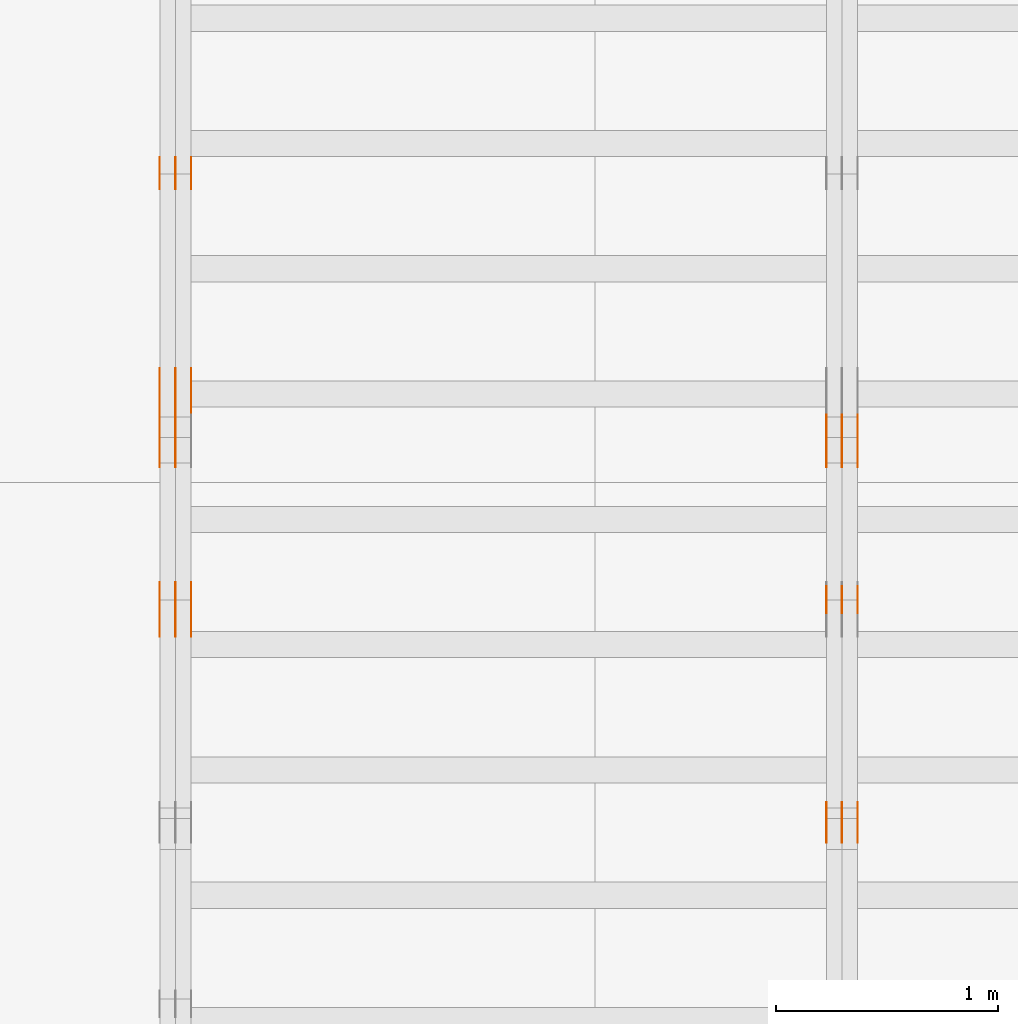
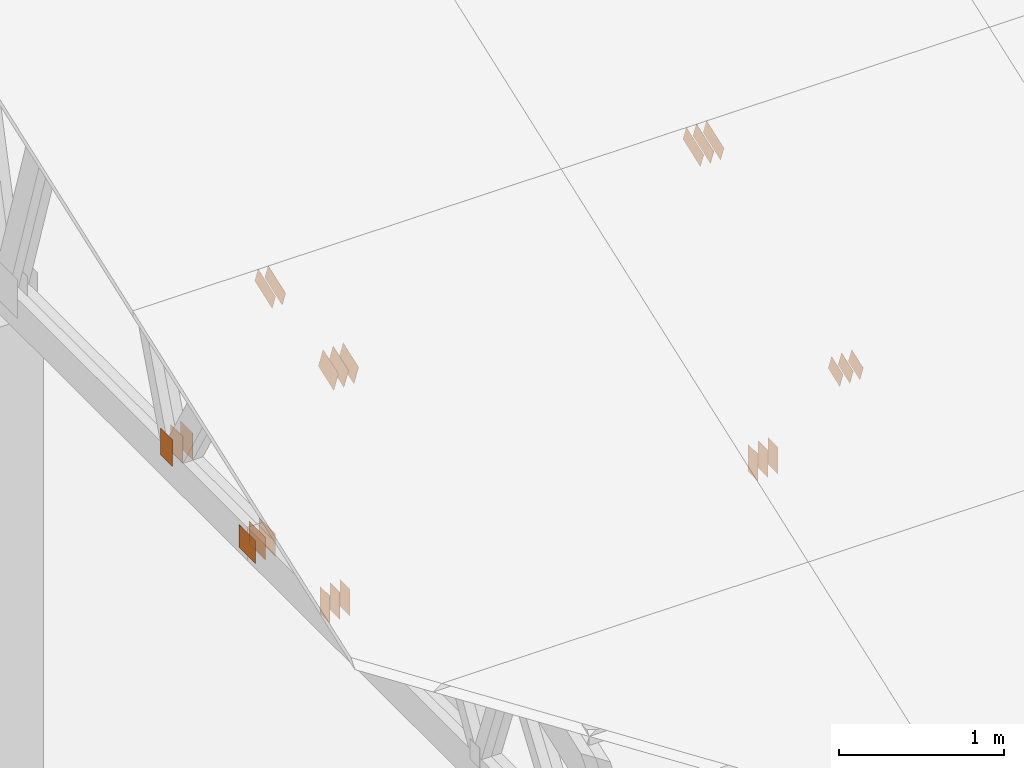
# One storey, part 70 of 189: 31 proxies.
"""IFC2X3 building model written with IfcOpenShell, lengths in millimetres."""

from ifc_helpers import new_model, entity, si_unit, converted_unit, derived_unit, direction, frame, frame_2d, origin, origin_2d_with_axis, place, context, subcontext, project, spatial, polyline, rectangle, outline, extrude, source, transform, mapped, material, type_object, type_shapes, element, save


model = new_model("IFC2X3")

# Units and contexts
model_context = context("Model", 3, precision=0.01, world=origin(), true_north=direction((6.12303176911189e-17, 1.0)))
body_context = subcontext(model_context, "Body", "Model", "MODEL_VIEW")
ifc_project = project(units=[si_unit("LENGTHUNIT", "METRE", prefix="MILLI"), si_unit("AREAUNIT", "SQUARE_METRE"), si_unit("VOLUMEUNIT", "CUBIC_METRE"), converted_unit("PLANEANGLEUNIT", "DEGREE", entity("IfcRatioMeasure", 0.0174532925199433), si_unit("PLANEANGLEUNIT", "RADIAN"), dimensions=[0, 0, 0, 0, 0, 0, 0]), si_unit("MASSUNIT", "GRAM", prefix="KILO"), derived_unit("MASSDENSITYUNIT", [(si_unit("MASSUNIT", "GRAM", prefix="KILO"), 1), (si_unit("LENGTHUNIT", "METRE"), -3)]), si_unit("TIMEUNIT", "SECOND"), si_unit("FREQUENCYUNIT", "HERTZ"), si_unit("THERMODYNAMICTEMPERATUREUNIT", "DEGREE_CELSIUS"), derived_unit("THERMALTRANSMITTANCEUNIT", [(si_unit("MASSUNIT", "GRAM", prefix="KILO"), 1), (si_unit("THERMODYNAMICTEMPERATUREUNIT", "KELVIN"), -1), (si_unit("TIMEUNIT", "SECOND"), -3)]), derived_unit("VOLUMETRICFLOWRATEUNIT", [(si_unit("LENGTHUNIT", "METRE"), 3), (si_unit("TIMEUNIT", "SECOND"), -1)]), si_unit("ELECTRICCURRENTUNIT", "AMPERE"), si_unit("ELECTRICVOLTAGEUNIT", "VOLT"), si_unit("POWERUNIT", "WATT"), si_unit("FORCEUNIT", "NEWTON"), si_unit("ILLUMINANCEUNIT", "LUX"), si_unit("LUMINOUSFLUXUNIT", "LUMEN"), si_unit("LUMINOUSINTENSITYUNIT", "CANDELA"), derived_unit("USERDEFINED", [(si_unit("MASSUNIT", "GRAM", prefix="KILO"), -1), (si_unit("LENGTHUNIT", "METRE"), -2), (si_unit("TIMEUNIT", "SECOND"), 3), (si_unit("LUMINOUSFLUXUNIT", "LUMEN"), 1)]), derived_unit("LINEARVELOCITYUNIT", [(si_unit("LENGTHUNIT", "METRE"), 1), (si_unit("TIMEUNIT", "SECOND"), -1)]), si_unit("PRESSUREUNIT", "PASCAL"), derived_unit("USERDEFINED", [(si_unit("LENGTHUNIT", "METRE"), -2), (si_unit("MASSUNIT", "GRAM", prefix="KILO"), 1), (si_unit("TIMEUNIT", "SECOND"), -2)])], contexts=[model_context])

# Site, building, storey
site_placement = place(None, origin())
site = spatial("IfcSite", under=ifc_project, at=site_placement, CompositionType="ELEMENT")
building_placement = place(site_placement, origin())
building = spatial("IfcBuilding", under=site, at=building_placement, CompositionType="ELEMENT")
storey_placement = place(building_placement, origin())
storey = spatial("IfcBuildingStorey", under=building, at=storey_placement, Name="Default", CompositionType="ELEMENT", Elevation=0.0)

# Proxies
ifc_material_1 = material(Name="IfcSurfaceStyle #27756")
building_element_proxy_type_1 = type_object("IfcBuildingElementProxyType", PredefinedType="NOTDEFINED", material=ifc_material_1)
shared_shape_1 = source(origin(), body_context, "Body", "SweptSolid", [
    extrude(outline(polyline([(-112.500654374667, -59.9999021691247), (112.500117969231, -59.9999021691247), (112.500612624162, 59.9999021691247), (-112.500076218726, 59.9999021691247), (-112.500654374667, -59.9999021691247)])), frame((112.500612624162, 60.0003514046321, 0.0), z_axis=(0.0, 0.0, 1.0), x_axis=(-1.0, 0.0, 0.0)), (0.0, 0.0, 1.0), 1.3),
])
type_shapes(building_element_proxy_type_1, [shared_shape_1])
proxy_1_placement = place(building_placement, frame((3336.3, 5418.0703125, 2162.37353515625), z_axis=(-1.0, 0.0, 0.0), x_axis=(0.0, 0.939692620785908, 0.342020143325669)))
element("IfcBuildingElementProxy", 1, at=proxy_1_placement, inside=storey, type_object=building_element_proxy_type_1, material=ifc_material_1, context=body_context, shape_type="MappedRepresentation", body=[
    mapped(shared_shape_1, transform((0.0, 0.0, 0.0), scale=1.0)),
])
ifc_material_2 = material(Name="IfcSurfaceStyle #27699")
building_element_proxy_type_2 = type_object("IfcBuildingElementProxyType", PredefinedType="NOTDEFINED", material=ifc_material_2)
shared_shape_2 = source(origin(), body_context, "Body", "SweptSolid", [
    extrude(outline(polyline([(-112.500654374667, -59.9999021691247), (112.500117969231, -59.9999021691247), (112.500612624162, 59.9999021691247), (-112.500076218726, 59.9999021691247), (-112.500654374667, -59.9999021691247)])), frame((112.500612624162, 60.0003514046321, 0.0), z_axis=(0.0, 0.0, 1.0), x_axis=(-1.0, 0.0, 0.0)), (0.0, 0.0, 1.0), 1.29999999999998),
])
type_shapes(building_element_proxy_type_2, [shared_shape_2])
proxy_2_placement = place(building_placement, frame((3265.0, 5418.0703125, 2162.37353515625), z_axis=(-1.0, 0.0, 0.0), x_axis=(0.0, 0.939692620785908, 0.342020143325669)))
element("IfcBuildingElementProxy", 2, at=proxy_2_placement, inside=storey, type_object=building_element_proxy_type_2, material=ifc_material_2, context=body_context, shape_type="MappedRepresentation", body=[
    mapped(shared_shape_2, transform((0.0, 0.0, 0.0), scale=1.0)),
])
ifc_material_3 = material(Name="IfcSurfaceStyle #27642")
building_element_proxy_type_3 = type_object("IfcBuildingElementProxyType", PredefinedType="NOTDEFINED", material=ifc_material_3)
shared_shape_3 = source(origin(), body_context, "Body", "SweptSolid", [
    extrude(outline(polyline([(-112.500654374667, -59.9999021691247), (112.500117969231, -59.9999021691247), (112.500612624162, 59.9999021691247), (-112.500076218726, 59.9999021691247), (-112.500654374667, -59.9999021691247)])), frame((112.500612624162, 60.0003514046321, 0.0), z_axis=(0.0, 0.0, 1.0), x_axis=(-1.0, 0.0, 0.0)), (0.0, 0.0, 1.0), 1.29999999999998),
])
type_shapes(building_element_proxy_type_3, [shared_shape_3])
proxy_3_placement = place(building_placement, frame((3266.3, 5418.0703125, 2162.37353515625), z_axis=(-1.0, 0.0, 0.0), x_axis=(0.0, 0.939692620785908, 0.342020143325669)))
element("IfcBuildingElementProxy", 3, at=proxy_3_placement, inside=storey, type_object=building_element_proxy_type_3, material=ifc_material_3, context=body_context, shape_type="MappedRepresentation", body=[
    mapped(shared_shape_3, transform((0.0, 0.0, 0.0), scale=1.0)),
])
ifc_material_4 = material(Name="IfcSurfaceStyle #27585")
building_element_proxy_type_4 = type_object("IfcBuildingElementProxyType", PredefinedType="NOTDEFINED", material=ifc_material_4)
shared_shape_4 = source(origin(), body_context, "Body", "SweptSolid", [
    extrude(outline(polyline([(-112.500654374667, -59.9999021691247), (112.500117969231, -59.9999021691247), (112.500612624162, 59.9999021691247), (-112.500076218726, 59.9999021691247), (-112.500654374667, -59.9999021691247)])), frame((112.500612624162, 60.0003514046321, 0.0), z_axis=(0.0, 0.0, 1.0), x_axis=(-1.0, 0.0, 0.0)), (0.0, 0.0, 1.0), 1.29999999999999),
])
type_shapes(building_element_proxy_type_4, [shared_shape_4])
proxy_4_placement = place(building_placement, frame((3195.0, 5418.0703125, 2162.37353515625), z_axis=(-1.0, 0.0, 0.0), x_axis=(0.0, 0.939692620785908, 0.342020143325669)))
element("IfcBuildingElementProxy", 4, at=proxy_4_placement, inside=storey, type_object=building_element_proxy_type_4, material=ifc_material_4, context=body_context, shape_type="MappedRepresentation", body=[
    mapped(shared_shape_4, transform((0.0, 0.0, 0.0), scale=1.0)),
])
ifc_material_5 = material(Name="IfcSurfaceStyle #27072")
building_element_proxy_type_5 = type_object("IfcBuildingElementProxyType", PredefinedType="NOTDEFINED", material=ifc_material_5)
shared_shape_5 = source(origin(), body_context, "Body", "SweptSolid", [
    extrude(rectangle(XDim=200.0, YDim=120.0, at=origin_2d_with_axis()), frame((100.0, 60.0, 0.0), z_axis=(0.0, 0.0, 1.0), x_axis=(-1.0, 0.0, 0.0)), (0.0, 0.0, 1.0), 1.3),
])
type_shapes(building_element_proxy_type_5, [shared_shape_5])
proxy_5_placement = place(building_placement, frame((3336.3, 4760.65625, 145.0), z_axis=(-1.0, 0.0, 0.0), x_axis=(0.0, 0.0, 1.0)))
element("IfcBuildingElementProxy", 5, at=proxy_5_placement, inside=storey, type_object=building_element_proxy_type_5, material=ifc_material_5, context=body_context, shape_type="MappedRepresentation", body=[
    mapped(shared_shape_5, transform((0.0, 0.0, 0.0), scale=1.0)),
])
ifc_material_6 = material(Name="IfcSurfaceStyle #27015")
building_element_proxy_type_6 = type_object("IfcBuildingElementProxyType", PredefinedType="NOTDEFINED", material=ifc_material_6)
shared_shape_6 = source(origin(), body_context, "Body", "SweptSolid", [
    extrude(rectangle(XDim=200.0, YDim=120.0, at=origin_2d_with_axis()), frame((100.0, 60.0, 0.0), z_axis=(0.0, 0.0, 1.0), x_axis=(-1.0, 0.0, 0.0)), (0.0, 0.0, 1.0), 1.29999999999998),
])
type_shapes(building_element_proxy_type_6, [shared_shape_6])
proxy_6_placement = place(building_placement, frame((3265.0, 4760.65625, 145.0), z_axis=(-1.0, 0.0, 0.0), x_axis=(0.0, 0.0, 1.0)))
element("IfcBuildingElementProxy", 6, at=proxy_6_placement, inside=storey, type_object=building_element_proxy_type_6, material=ifc_material_6, context=body_context, shape_type="MappedRepresentation", body=[
    mapped(shared_shape_6, transform((0.0, 0.0, 0.0), scale=1.0)),
])
ifc_material_7 = material(Name="IfcSurfaceStyle #26958")
building_element_proxy_type_7 = type_object("IfcBuildingElementProxyType", PredefinedType="NOTDEFINED", material=ifc_material_7)
shared_shape_7 = source(origin(), body_context, "Body", "SweptSolid", [
    extrude(rectangle(XDim=200.0, YDim=120.0, at=origin_2d_with_axis()), frame((100.0, 60.0, 0.0), z_axis=(0.0, 0.0, 1.0), x_axis=(-1.0, 0.0, 0.0)), (0.0, 0.0, 1.0), 1.29999999999998),
])
type_shapes(building_element_proxy_type_7, [shared_shape_7])
proxy_7_placement = place(building_placement, frame((3266.3, 4760.65625, 145.0), z_axis=(-1.0, 0.0, 0.0), x_axis=(0.0, 0.0, 1.0)))
element("IfcBuildingElementProxy", 7, at=proxy_7_placement, inside=storey, type_object=building_element_proxy_type_7, material=ifc_material_7, context=body_context, shape_type="MappedRepresentation", body=[
    mapped(shared_shape_7, transform((0.0, 0.0, 0.0), scale=1.0)),
])
ifc_material_8 = material(Name="IfcSurfaceStyle #26901")
building_element_proxy_type_8 = type_object("IfcBuildingElementProxyType", PredefinedType="NOTDEFINED", material=ifc_material_8)
shared_shape_8 = source(origin(), body_context, "Body", "SweptSolid", [
    extrude(rectangle(XDim=200.0, YDim=120.0, at=origin_2d_with_axis()), frame((100.0, 60.0, 0.0), z_axis=(0.0, 0.0, 1.0), x_axis=(-1.0, 0.0, 0.0)), (0.0, 0.0, 1.0), 1.29999999999999),
])
type_shapes(building_element_proxy_type_8, [shared_shape_8])
proxy_8_placement = place(building_placement, frame((3195.0, 4760.65625, 145.0), z_axis=(-1.0, 0.0, 0.0), x_axis=(0.0, 0.0, 1.0)))
element("IfcBuildingElementProxy", 8, at=proxy_8_placement, inside=storey, type_object=building_element_proxy_type_8, material=ifc_material_8, context=body_context, shape_type="MappedRepresentation", body=[
    mapped(shared_shape_8, transform((0.0, 0.0, 0.0), scale=1.0)),
])
ifc_material_9 = material(Name="IfcSurfaceStyle #26844")
building_element_proxy_type_9 = type_object("IfcBuildingElementProxyType", PredefinedType="NOTDEFINED", material=ifc_material_9)
shared_shape_9 = source(origin(), body_context, "Body", "SweptSolid", [
    extrude(outline(polyline([(-74.9994515581384, -59.9999039432178), (74.9998536965286, -59.9999039432178), (75.0003483514593, 59.9999039432178), (-75.0007504898495, 59.9999039432178), (-74.9994515581384, -59.9999039432178)])), frame((75.0003483514593, 60.0003496305408, 0.0), z_axis=(0.0, 0.0, 1.0), x_axis=(-1.0, 0.0, 0.0)), (0.0, 0.0, 1.0), 1.3),
])
type_shapes(building_element_proxy_type_9, [shared_shape_9])
proxy_9_placement = place(building_placement, frame((3336.3, 3726.8984375, 1559.607421875), z_axis=(-1.0, 0.0, 0.0), x_axis=(0.0, 0.939692620785908, 0.342020143325669)))
element("IfcBuildingElementProxy", 9, at=proxy_9_placement, inside=storey, type_object=building_element_proxy_type_9, material=ifc_material_9, context=body_context, shape_type="MappedRepresentation", body=[
    mapped(shared_shape_9, transform((0.0, 0.0, 0.0), scale=1.0)),
])
ifc_material_10 = material(Name="IfcSurfaceStyle #26787")
building_element_proxy_type_10 = type_object("IfcBuildingElementProxyType", PredefinedType="NOTDEFINED", material=ifc_material_10)
shared_shape_10 = source(origin(), body_context, "Body", "SweptSolid", [
    extrude(outline(polyline([(-74.9994515581384, -59.9999039432178), (74.9998536965286, -59.9999039432178), (75.0003483514593, 59.9999039432178), (-75.0007504898495, 59.9999039432178), (-74.9994515581384, -59.9999039432178)])), frame((75.0003483514593, 60.0003496305408, 0.0), z_axis=(0.0, 0.0, 1.0), x_axis=(-1.0, 0.0, 0.0)), (0.0, 0.0, 1.0), 1.29999999999999),
])
type_shapes(building_element_proxy_type_10, [shared_shape_10])
proxy_10_placement = place(building_placement, frame((3265.0, 3726.8984375, 1559.607421875), z_axis=(-1.0, 0.0, 0.0), x_axis=(0.0, 0.939692620785908, 0.342020143325669)))
element("IfcBuildingElementProxy", 10, at=proxy_10_placement, inside=storey, type_object=building_element_proxy_type_10, material=ifc_material_10, context=body_context, shape_type="MappedRepresentation", body=[
    mapped(shared_shape_10, transform((0.0, 0.0, 0.0), scale=1.0)),
])
ifc_material_11 = material(Name="IfcSurfaceStyle #26730")
building_element_proxy_type_11 = type_object("IfcBuildingElementProxyType", PredefinedType="NOTDEFINED", material=ifc_material_11)
shared_shape_11 = source(origin(), body_context, "Body", "SweptSolid", [
    extrude(outline(polyline([(-74.9994515581384, -59.9999039432178), (74.9998536965286, -59.9999039432178), (75.0003483514593, 59.9999039432178), (-75.0007504898495, 59.9999039432178), (-74.9994515581384, -59.9999039432178)])), frame((75.0003483514593, 60.0003496305408, 0.0), z_axis=(0.0, 0.0, 1.0), x_axis=(-1.0, 0.0, 0.0)), (0.0, 0.0, 1.0), 1.29999999999999),
])
type_shapes(building_element_proxy_type_11, [shared_shape_11])
proxy_11_placement = place(building_placement, frame((3266.3, 3726.8984375, 1559.607421875), z_axis=(-1.0, 0.0, 0.0), x_axis=(0.0, 0.939692620785908, 0.342020143325669)))
element("IfcBuildingElementProxy", 11, at=proxy_11_placement, inside=storey, type_object=building_element_proxy_type_11, material=ifc_material_11, context=body_context, shape_type="MappedRepresentation", body=[
    mapped(shared_shape_11, transform((0.0, 0.0, 0.0), scale=1.0)),
])
ifc_material_12 = material(Name="IfcSurfaceStyle #26673")
building_element_proxy_type_12 = type_object("IfcBuildingElementProxyType", PredefinedType="NOTDEFINED", material=ifc_material_12)
shared_shape_12 = source(origin(), body_context, "Body", "SweptSolid", [
    extrude(outline(polyline([(-74.9994515581384, -59.9999039432178), (74.9998536965286, -59.9999039432178), (75.0003483514593, 59.9999039432178), (-75.0007504898495, 59.9999039432178), (-74.9994515581384, -59.9999039432178)])), frame((75.0003483514593, 60.0003496305408, 0.0), z_axis=(0.0, 0.0, 1.0), x_axis=(-1.0, 0.0, 0.0)), (0.0, 0.0, 1.0), 1.29999999999999),
])
type_shapes(building_element_proxy_type_12, [shared_shape_12])
proxy_12_placement = place(building_placement, frame((3195.0, 3726.8984375, 1559.607421875), z_axis=(-1.0, 0.0, 0.0), x_axis=(0.0, 0.939692620785908, 0.342020143325669)))
element("IfcBuildingElementProxy", 12, at=proxy_12_placement, inside=storey, type_object=building_element_proxy_type_12, material=ifc_material_12, context=body_context, shape_type="MappedRepresentation", body=[
    mapped(shared_shape_12, transform((0.0, 0.0, 0.0), scale=1.0)),
])
ifc_material_13 = material(Name="IfcSurfaceStyle #15839")
building_element_proxy_type_13 = type_object("IfcBuildingElementProxyType", PredefinedType="NOTDEFINED", material=ifc_material_13)
shared_shape_13 = source(origin(), body_context, "Body", "SweptSolid", [
    extrude(rectangle(XDim=200.0, YDim=144.0, at=frame_2d((1.4210854715202e-14, 0.0), x_axis=(1.0, 0.0))), frame((100.0, 72.0, 0.0), z_axis=(0.0, 0.0, 1.0), x_axis=(-1.0, 0.0, 0.0)), (0.0, 0.0, 1.0), 1.3),
])
type_shapes(building_element_proxy_type_13, [shared_shape_13])
proxy_13_placement = place(building_placement, frame((336.3, 6668.833984375, 145.0), z_axis=(-1.0, 0.0, 0.0), x_axis=(0.0, 0.0, 1.0)))
element("IfcBuildingElementProxy", 13, at=proxy_13_placement, inside=storey, type_object=building_element_proxy_type_13, material=ifc_material_13, context=body_context, shape_type="MappedRepresentation", body=[
    mapped(shared_shape_13, transform((0.0, 0.0, 0.0), scale=1.0)),
])
ifc_material_14 = material(Name="IfcSurfaceStyle #15782")
building_element_proxy_type_14 = type_object("IfcBuildingElementProxyType", PredefinedType="NOTDEFINED", material=ifc_material_14)
shared_shape_14 = source(origin(), body_context, "Body", "SweptSolid", [
    extrude(rectangle(XDim=200.0, YDim=144.0, at=frame_2d((1.4210854715202e-14, 0.0), x_axis=(1.0, 0.0))), frame((100.0, 72.0, 0.0), z_axis=(0.0, 0.0, 1.0), x_axis=(-1.0, 0.0, 0.0)), (0.0, 0.0, 1.0), 1.29999999999998),
])
type_shapes(building_element_proxy_type_14, [shared_shape_14])
proxy_14_placement = place(building_placement, frame((265.0, 6668.833984375, 145.0), z_axis=(-1.0, 0.0, 0.0), x_axis=(0.0, 0.0, 1.0)))
element("IfcBuildingElementProxy", 14, at=proxy_14_placement, inside=storey, type_object=building_element_proxy_type_14, material=ifc_material_14, context=body_context, shape_type="MappedRepresentation", body=[
    mapped(shared_shape_14, transform((0.0, 0.0, 0.0), scale=1.0)),
])
ifc_material_15 = material(Name="IfcSurfaceStyle #15725")
building_element_proxy_type_15 = type_object("IfcBuildingElementProxyType", PredefinedType="NOTDEFINED", material=ifc_material_15)
shared_shape_15 = source(origin(), body_context, "Body", "SweptSolid", [
    extrude(rectangle(XDim=200.0, YDim=144.0, at=frame_2d((1.4210854715202e-14, 0.0), x_axis=(1.0, 0.0))), frame((100.0, 72.0, 0.0), z_axis=(0.0, 0.0, 1.0), x_axis=(-1.0, 0.0, 0.0)), (0.0, 0.0, 1.0), 1.29999999999998),
])
type_shapes(building_element_proxy_type_15, [shared_shape_15])
proxy_15_placement = place(building_placement, frame((266.3, 6668.833984375, 145.0), z_axis=(-1.0, 0.0, 0.0), x_axis=(0.0, 0.0, 1.0)))
element("IfcBuildingElementProxy", 15, at=proxy_15_placement, inside=storey, type_object=building_element_proxy_type_15, material=ifc_material_15, context=body_context, shape_type="MappedRepresentation", body=[
    mapped(shared_shape_15, transform((0.0, 0.0, 0.0), scale=1.0)),
])
ifc_material_16 = material(Name="IfcSurfaceStyle #15668")
building_element_proxy_type_16 = type_object("IfcBuildingElementProxyType", PredefinedType="NOTDEFINED", material=ifc_material_16)
shared_shape_16 = source(origin(), body_context, "Body", "SweptSolid", [
    extrude(rectangle(XDim=200.0, YDim=144.0, at=frame_2d((1.4210854715202e-14, 0.0), x_axis=(1.0, 0.0))), frame((100.0, 72.0, 0.0), z_axis=(0.0, 0.0, 1.0), x_axis=(-1.0, 0.0, 0.0)), (0.0, 0.0, 1.0), 1.29999999999999),
])
type_shapes(building_element_proxy_type_16, [shared_shape_16])
proxy_16_placement = place(building_placement, frame((195.0, 6668.833984375, 145.0), z_axis=(-1.0, 0.0, 0.0), x_axis=(0.0, 0.0, 1.0)))
element("IfcBuildingElementProxy", 16, at=proxy_16_placement, inside=storey, type_object=building_element_proxy_type_16, material=ifc_material_16, context=body_context, shape_type="MappedRepresentation", body=[
    mapped(shared_shape_16, transform((0.0, 0.0, 0.0), scale=1.0)),
])
ifc_material_17 = material(Name="IfcSurfaceStyle #15611")
building_element_proxy_type_17 = type_object("IfcBuildingElementProxyType", PredefinedType="NOTDEFINED", material=ifc_material_17)
shared_shape_17 = source(origin(), body_context, "Body", "SweptSolid", [
    extrude(rectangle(XDim=200.0, YDim=168.0, at=origin_2d_with_axis()), frame((100.0, 84.0, 0.0), z_axis=(0.0, 0.0, 1.0), x_axis=(-1.0, 0.0, 0.0)), (0.0, 0.0, 1.0), 1.3),
])
type_shapes(building_element_proxy_type_17, [shared_shape_17])
proxy_17_placement = place(building_placement, frame((336.3, 5662.466796875, 206.5), z_axis=(-1.0, 0.0, 0.0), x_axis=(0.0, 1.0, 0.0)))
element("IfcBuildingElementProxy", 17, at=proxy_17_placement, inside=storey, type_object=building_element_proxy_type_17, material=ifc_material_17, context=body_context, shape_type="MappedRepresentation", body=[
    mapped(shared_shape_17, transform((0.0, 0.0, 0.0), scale=1.0)),
])
ifc_material_18 = material(Name="IfcSurfaceStyle #15554")
building_element_proxy_type_18 = type_object("IfcBuildingElementProxyType", PredefinedType="NOTDEFINED", material=ifc_material_18)
shared_shape_18 = source(origin(), body_context, "Body", "SweptSolid", [
    extrude(rectangle(XDim=200.0, YDim=168.0, at=origin_2d_with_axis()), frame((100.0, 84.0, 0.0), z_axis=(0.0, 0.0, 1.0), x_axis=(-1.0, 0.0, 0.0)), (0.0, 0.0, 1.0), 1.29999999999998),
])
type_shapes(building_element_proxy_type_18, [shared_shape_18])
proxy_18_placement = place(building_placement, frame((265.0, 5662.466796875, 206.5), z_axis=(-1.0, 0.0, 0.0), x_axis=(0.0, 1.0, 0.0)))
element("IfcBuildingElementProxy", 18, at=proxy_18_placement, inside=storey, type_object=building_element_proxy_type_18, material=ifc_material_18, context=body_context, shape_type="MappedRepresentation", body=[
    mapped(shared_shape_18, transform((0.0, 0.0, 0.0), scale=1.0)),
])
ifc_material_19 = material(Name="IfcSurfaceStyle #15497")
building_element_proxy_type_19 = type_object("IfcBuildingElementProxyType", PredefinedType="NOTDEFINED", material=ifc_material_19)
shared_shape_19 = source(origin(), body_context, "Body", "SweptSolid", [
    extrude(rectangle(XDim=200.0, YDim=168.0, at=origin_2d_with_axis()), frame((100.0, 84.0, 0.0), z_axis=(0.0, 0.0, 1.0), x_axis=(-1.0, 0.0, 0.0)), (0.0, 0.0, 1.0), 1.29999999999998),
])
type_shapes(building_element_proxy_type_19, [shared_shape_19])
proxy_19_placement = place(building_placement, frame((266.3, 5662.466796875, 206.5), z_axis=(-1.0, 0.0, 0.0), x_axis=(0.0, 1.0, 0.0)))
element("IfcBuildingElementProxy", 19, at=proxy_19_placement, inside=storey, type_object=building_element_proxy_type_19, material=ifc_material_19, context=body_context, shape_type="MappedRepresentation", body=[
    mapped(shared_shape_19, transform((0.0, 0.0, 0.0), scale=1.0)),
])
ifc_material_20 = material(Name="IfcSurfaceStyle #15440")
building_element_proxy_type_20 = type_object("IfcBuildingElementProxyType", PredefinedType="NOTDEFINED", material=ifc_material_20)
shared_shape_20 = source(origin(), body_context, "Body", "SweptSolid", [
    extrude(rectangle(XDim=200.0, YDim=168.0, at=origin_2d_with_axis()), frame((100.0, 84.0, 0.0), z_axis=(0.0, 0.0, 1.0), x_axis=(-1.0, 0.0, 0.0)), (0.0, 0.0, 1.0), 1.29999999999999),
])
type_shapes(building_element_proxy_type_20, [shared_shape_20])
proxy_20_placement = place(building_placement, frame((195.0, 5662.466796875, 206.5), z_axis=(-1.0, 0.0, 0.0), x_axis=(0.0, 1.0, 0.0)))
element("IfcBuildingElementProxy", 20, at=proxy_20_placement, inside=storey, type_object=building_element_proxy_type_20, material=ifc_material_20, context=body_context, shape_type="MappedRepresentation", body=[
    mapped(shared_shape_20, transform((0.0, 0.0, 0.0), scale=1.0)),
])
ifc_material_21 = material(Name="IfcSurfaceStyle #11906")
building_element_proxy_type_21 = type_object("IfcBuildingElementProxyType", PredefinedType="NOTDEFINED", material=ifc_material_21)
shared_shape_21 = source(origin(), body_context, "Body", "SweptSolid", [
    extrude(outline(polyline([(-112.500654374667, -59.9999021691247), (112.500117969231, -59.9999021691247), (112.500612624162, 59.9999021691247), (-112.500076218726, 59.9999021691247), (-112.500654374667, -59.9999021691247)])), frame((112.500612624162, 60.0003514046321, 0.0), z_axis=(0.0, 0.0, 1.0), x_axis=(-1.0, 0.0, 0.0)), (0.0, 0.0, 1.0), 1.29999999999998),
])
type_shapes(building_element_proxy_type_21, [shared_shape_21])
proxy_21_placement = place(building_placement, frame((265.0, 5418.0703125, 2162.37353515625), z_axis=(-1.0, 0.0, 0.0), x_axis=(0.0, 0.939692620785908, 0.342020143325669)))
element("IfcBuildingElementProxy", 21, at=proxy_21_placement, inside=storey, type_object=building_element_proxy_type_21, material=ifc_material_21, context=body_context, shape_type="MappedRepresentation", body=[
    mapped(shared_shape_21, transform((0.0, 0.0, 0.0), scale=1.0)),
])
ifc_material_22 = material(Name="IfcSurfaceStyle #11849")
building_element_proxy_type_22 = type_object("IfcBuildingElementProxyType", PredefinedType="NOTDEFINED", material=ifc_material_22)
shared_shape_22 = source(origin(), body_context, "Body", "SweptSolid", [
    extrude(outline(polyline([(-112.500654374667, -59.9999021691247), (112.500117969231, -59.9999021691247), (112.500612624162, 59.9999021691247), (-112.500076218726, 59.9999021691247), (-112.500654374667, -59.9999021691247)])), frame((112.500612624162, 60.0003514046321, 0.0), z_axis=(0.0, 0.0, 1.0), x_axis=(-1.0, 0.0, 0.0)), (0.0, 0.0, 1.0), 1.29999999999998),
])
type_shapes(building_element_proxy_type_22, [shared_shape_22])
proxy_22_placement = place(building_placement, frame((266.3, 5418.0703125, 2162.37353515625), z_axis=(-1.0, 0.0, 0.0), x_axis=(0.0, 0.939692620785908, 0.342020143325669)))
element("IfcBuildingElementProxy", 22, at=proxy_22_placement, inside=storey, type_object=building_element_proxy_type_22, material=ifc_material_22, context=body_context, shape_type="MappedRepresentation", body=[
    mapped(shared_shape_22, transform((0.0, 0.0, 0.0), scale=1.0)),
])
ifc_material_23 = material(Name="IfcSurfaceStyle #11792")
building_element_proxy_type_23 = type_object("IfcBuildingElementProxyType", PredefinedType="NOTDEFINED", material=ifc_material_23)
shared_shape_23 = source(origin(), body_context, "Body", "SweptSolid", [
    extrude(outline(polyline([(-112.500654374667, -59.9999021691247), (112.500117969231, -59.9999021691247), (112.500612624162, 59.9999021691247), (-112.500076218726, 59.9999021691247), (-112.500654374667, -59.9999021691247)])), frame((112.500612624162, 60.0003514046321, 0.0), z_axis=(0.0, 0.0, 1.0), x_axis=(-1.0, 0.0, 0.0)), (0.0, 0.0, 1.0), 1.29999999999999),
])
type_shapes(building_element_proxy_type_23, [shared_shape_23])
proxy_23_placement = place(building_placement, frame((195.0, 5418.0703125, 2162.37353515625), z_axis=(-1.0, 0.0, 0.0), x_axis=(0.0, 0.939692620785908, 0.342020143325669)))
element("IfcBuildingElementProxy", 23, at=proxy_23_placement, inside=storey, type_object=building_element_proxy_type_23, material=ifc_material_23, context=body_context, shape_type="MappedRepresentation", body=[
    mapped(shared_shape_23, transform((0.0, 0.0, 0.0), scale=1.0)),
])
ifc_material_24 = material(Name="IfcSurfaceStyle #11279")
building_element_proxy_type_24 = type_object("IfcBuildingElementProxyType", PredefinedType="NOTDEFINED", material=ifc_material_24)
shared_shape_24 = source(origin(), body_context, "Body", "SweptSolid", [
    extrude(rectangle(XDim=200.0, YDim=120.0, at=origin_2d_with_axis()), frame((100.0, 60.0, 0.0), z_axis=(0.0, 0.0, 1.0), x_axis=(-1.0, 0.0, 0.0)), (0.0, 0.0, 1.0), 1.3),
])
type_shapes(building_element_proxy_type_24, [shared_shape_24])
proxy_24_placement = place(building_placement, frame((336.3, 4760.65625, 145.0), z_axis=(-1.0, 0.0, 0.0), x_axis=(0.0, 0.0, 1.0)))
element("IfcBuildingElementProxy", 24, at=proxy_24_placement, inside=storey, type_object=building_element_proxy_type_24, material=ifc_material_24, context=body_context, shape_type="MappedRepresentation", body=[
    mapped(shared_shape_24, transform((0.0, 0.0, 0.0), scale=1.0)),
])
ifc_material_25 = material(Name="IfcSurfaceStyle #11222")
building_element_proxy_type_25 = type_object("IfcBuildingElementProxyType", PredefinedType="NOTDEFINED", material=ifc_material_25)
shared_shape_25 = source(origin(), body_context, "Body", "SweptSolid", [
    extrude(rectangle(XDim=200.0, YDim=120.0, at=origin_2d_with_axis()), frame((100.0, 60.0, 0.0), z_axis=(0.0, 0.0, 1.0), x_axis=(-1.0, 0.0, 0.0)), (0.0, 0.0, 1.0), 1.29999999999998),
])
type_shapes(building_element_proxy_type_25, [shared_shape_25])
proxy_25_placement = place(building_placement, frame((265.0, 4760.65625, 145.0), z_axis=(-1.0, 0.0, 0.0), x_axis=(0.0, 0.0, 1.0)))
element("IfcBuildingElementProxy", 25, at=proxy_25_placement, inside=storey, type_object=building_element_proxy_type_25, material=ifc_material_25, context=body_context, shape_type="MappedRepresentation", body=[
    mapped(shared_shape_25, transform((0.0, 0.0, 0.0), scale=1.0)),
])
ifc_material_26 = material(Name="IfcSurfaceStyle #11165")
building_element_proxy_type_26 = type_object("IfcBuildingElementProxyType", PredefinedType="NOTDEFINED", material=ifc_material_26)
shared_shape_26 = source(origin(), body_context, "Body", "SweptSolid", [
    extrude(rectangle(XDim=200.0, YDim=120.0, at=origin_2d_with_axis()), frame((100.0, 60.0, 0.0), z_axis=(0.0, 0.0, 1.0), x_axis=(-1.0, 0.0, 0.0)), (0.0, 0.0, 1.0), 1.29999999999998),
])
type_shapes(building_element_proxy_type_26, [shared_shape_26])
proxy_26_placement = place(building_placement, frame((266.3, 4760.65625, 145.0), z_axis=(-1.0, 0.0, 0.0), x_axis=(0.0, 0.0, 1.0)))
element("IfcBuildingElementProxy", 26, at=proxy_26_placement, inside=storey, type_object=building_element_proxy_type_26, material=ifc_material_26, context=body_context, shape_type="MappedRepresentation", body=[
    mapped(shared_shape_26, transform((0.0, 0.0, 0.0), scale=1.0)),
])
ifc_material_27 = material(Name="IfcSurfaceStyle #11108")
building_element_proxy_type_27 = type_object("IfcBuildingElementProxyType", PredefinedType="NOTDEFINED", material=ifc_material_27)
shared_shape_27 = source(origin(), body_context, "Body", "SweptSolid", [
    extrude(rectangle(XDim=200.0, YDim=120.0, at=origin_2d_with_axis()), frame((100.0, 60.0, 0.0), z_axis=(0.0, 0.0, 1.0), x_axis=(-1.0, 0.0, 0.0)), (0.0, 0.0, 1.0), 1.29999999999999),
])
type_shapes(building_element_proxy_type_27, [shared_shape_27])
proxy_27_placement = place(building_placement, frame((195.0, 4760.65625, 145.0), z_axis=(-1.0, 0.0, 0.0), x_axis=(0.0, 0.0, 1.0)))
element("IfcBuildingElementProxy", 27, at=proxy_27_placement, inside=storey, type_object=building_element_proxy_type_27, material=ifc_material_27, context=body_context, shape_type="MappedRepresentation", body=[
    mapped(shared_shape_27, transform((0.0, 0.0, 0.0), scale=1.0)),
])
ifc_material_28 = material(Name="IfcSurfaceStyle #6383")
building_element_proxy_type_28 = type_object("IfcBuildingElementProxyType", PredefinedType="NOTDEFINED", material=ifc_material_28)
shared_shape_28 = source(origin(), body_context, "Body", "SweptSolid", [
    extrude(outline(polyline([(-99.9993269270171, -84.0000832532405), (99.9997189122032, -84.0000832532405), (99.9992851765118, 84.0000832532405), (-99.999677161698, 84.0000832532405), (-99.9993269270171, -84.0000832532405)])), frame((99.9999283659736, 84.0000832532405, 0.0), z_axis=(0.0, 0.0, 1.0), x_axis=(-1.0, 0.0, 0.0)), (0.0, 0.0, 1.0), 1.3),
])
type_shapes(building_element_proxy_type_28, [shared_shape_28])
proxy_28_placement = place(building_placement, frame((336.3, 4654.06379965055, 2052.96988554922), z_axis=(-1.0, 0.0, 0.0), x_axis=(0.0, 0.939692620785908, 0.342020143325669)))
element("IfcBuildingElementProxy", 28, at=proxy_28_placement, inside=storey, type_object=building_element_proxy_type_28, material=ifc_material_28, context=body_context, shape_type="MappedRepresentation", body=[
    mapped(shared_shape_28, transform((0.0, 0.0, 0.0), scale=1.0)),
])
ifc_material_29 = material(Name="IfcSurfaceStyle #6326")
building_element_proxy_type_29 = type_object("IfcBuildingElementProxyType", PredefinedType="NOTDEFINED", material=ifc_material_29)
shared_shape_29 = source(origin(), body_context, "Body", "SweptSolid", [
    extrude(outline(polyline([(-99.9993269270171, -84.0000832532405), (99.9997189122032, -84.0000832532405), (99.9992851765118, 84.0000832532405), (-99.999677161698, 84.0000832532405), (-99.9993269270171, -84.0000832532405)])), frame((99.9999283659736, 84.0000832532405, 0.0), z_axis=(0.0, 0.0, 1.0), x_axis=(-1.0, 0.0, 0.0)), (0.0, 0.0, 1.0), 1.29999999999998),
])
type_shapes(building_element_proxy_type_29, [shared_shape_29])
proxy_29_placement = place(building_placement, frame((265.0, 4654.06379965055, 2052.96988554922), z_axis=(-1.0, 0.0, 0.0), x_axis=(0.0, 0.939692620785908, 0.342020143325669)))
element("IfcBuildingElementProxy", 29, at=proxy_29_placement, inside=storey, type_object=building_element_proxy_type_29, material=ifc_material_29, context=body_context, shape_type="MappedRepresentation", body=[
    mapped(shared_shape_29, transform((0.0, 0.0, 0.0), scale=1.0)),
])
ifc_material_30 = material(Name="IfcSurfaceStyle #6269")
building_element_proxy_type_30 = type_object("IfcBuildingElementProxyType", PredefinedType="NOTDEFINED", material=ifc_material_30)
shared_shape_30 = source(origin(), body_context, "Body", "SweptSolid", [
    extrude(outline(polyline([(-99.9993269270171, -84.0000832532405), (99.9997189122032, -84.0000832532405), (99.9992851765118, 84.0000832532405), (-99.999677161698, 84.0000832532405), (-99.9993269270171, -84.0000832532405)])), frame((99.9999283659736, 84.0000832532405, 0.0), z_axis=(0.0, 0.0, 1.0), x_axis=(-1.0, 0.0, 0.0)), (0.0, 0.0, 1.0), 1.29999999999998),
])
type_shapes(building_element_proxy_type_30, [shared_shape_30])
proxy_30_placement = place(building_placement, frame((266.3, 4654.06379965055, 2052.96988554922), z_axis=(-1.0, 0.0, 0.0), x_axis=(0.0, 0.939692620785908, 0.342020143325669)))
element("IfcBuildingElementProxy", 30, at=proxy_30_placement, inside=storey, type_object=building_element_proxy_type_30, material=ifc_material_30, context=body_context, shape_type="MappedRepresentation", body=[
    mapped(shared_shape_30, transform((0.0, 0.0, 0.0), scale=1.0)),
])
ifc_material_31 = material(Name="IfcSurfaceStyle #6212")
building_element_proxy_type_31 = type_object("IfcBuildingElementProxyType", PredefinedType="NOTDEFINED", material=ifc_material_31)
shared_shape_31 = source(origin(), body_context, "Body", "SweptSolid", [
    extrude(outline(polyline([(-99.9993269270171, -84.0000832532405), (99.9997189122032, -84.0000832532405), (99.9992851765118, 84.0000832532405), (-99.999677161698, 84.0000832532405), (-99.9993269270171, -84.0000832532405)])), frame((99.9999283659736, 84.0000832532405, 0.0), z_axis=(0.0, 0.0, 1.0), x_axis=(-1.0, 0.0, 0.0)), (0.0, 0.0, 1.0), 1.29999999999999),
])
type_shapes(building_element_proxy_type_31, [shared_shape_31])
proxy_31_placement = place(building_placement, frame((195.0, 4654.06379965055, 2052.96988554922), z_axis=(-1.0, 0.0, 0.0), x_axis=(0.0, 0.939692620785908, 0.342020143325669)))
element("IfcBuildingElementProxy", 31, at=proxy_31_placement, inside=storey, type_object=building_element_proxy_type_31, material=ifc_material_31, context=body_context, shape_type="MappedRepresentation", body=[
    mapped(shared_shape_31, transform((0.0, 0.0, 0.0), scale=1.0)),
])

save(model, "model.ifc")
